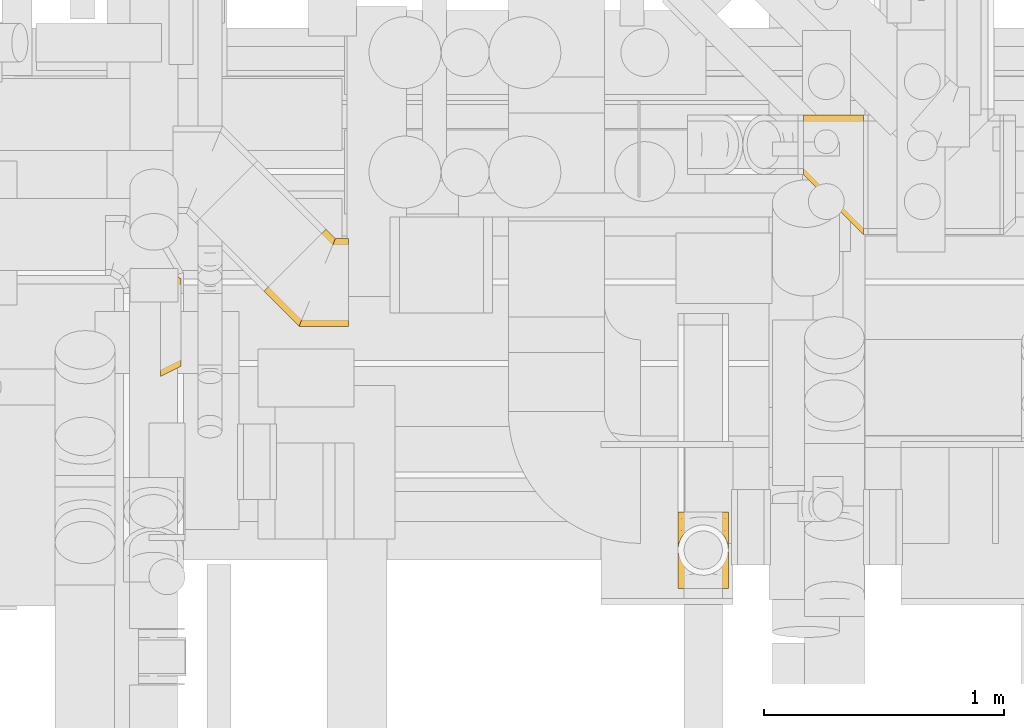
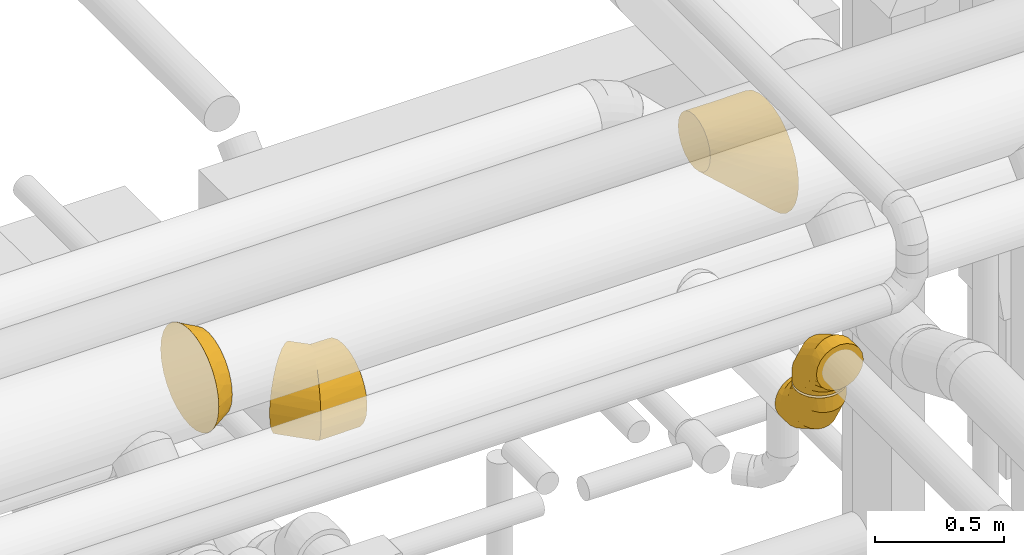
# One storey, part 14 of 337: 5 coverings.
"""IFC2X3 building model written with IfcOpenShell, lengths in millimetres."""

from ifc_helpers import new_model, entity, si_unit, converted_unit, derived_unit, direction, frame, origin, place, context, subcontext, project, spatial, faceted_brep, element, save


model = new_model("IFC2X3")

# Units and contexts
model_context = context("Model", 3, precision=0.01, world=origin(), true_north=direction((6.12303176911189e-17, 1.0)))
body_context = subcontext(model_context, "Body", "Model", "MODEL_VIEW")
ifc_project = project(units=[si_unit("LENGTHUNIT", "METRE", prefix="MILLI"), si_unit("AREAUNIT", "SQUARE_METRE"), si_unit("VOLUMEUNIT", "CUBIC_METRE"), converted_unit("PLANEANGLEUNIT", "DEGREE", entity("IfcRatioMeasure", 0.0174532925199433), si_unit("PLANEANGLEUNIT", "RADIAN"), dimensions=[0, 0, 0, 0, 0, 0, 0]), si_unit("MASSUNIT", "GRAM", prefix="KILO"), derived_unit("MASSDENSITYUNIT", [(si_unit("MASSUNIT", "GRAM", prefix="KILO"), 1), (si_unit("LENGTHUNIT", "METRE"), -3)]), derived_unit("MOMENTOFINERTIAUNIT", [(si_unit("LENGTHUNIT", "METRE"), 4)]), si_unit("TIMEUNIT", "SECOND"), si_unit("FREQUENCYUNIT", "HERTZ"), si_unit("THERMODYNAMICTEMPERATUREUNIT", "DEGREE_CELSIUS"), derived_unit("THERMALTRANSMITTANCEUNIT", [(si_unit("MASSUNIT", "GRAM", prefix="KILO"), 1), (si_unit("THERMODYNAMICTEMPERATUREUNIT", "KELVIN"), -1), (si_unit("TIMEUNIT", "SECOND"), -3)]), derived_unit("VOLUMETRICFLOWRATEUNIT", [(si_unit("LENGTHUNIT", "METRE"), 3), (si_unit("TIMEUNIT", "SECOND"), -1)]), derived_unit("MASSFLOWRATEUNIT", [(si_unit("MASSUNIT", "GRAM", prefix="KILO"), 1), (si_unit("TIMEUNIT", "SECOND"), -1)]), derived_unit("ROTATIONALFREQUENCYUNIT", [(si_unit("TIMEUNIT", "SECOND"), -1)]), si_unit("ELECTRICCURRENTUNIT", "AMPERE"), si_unit("ELECTRICVOLTAGEUNIT", "VOLT"), si_unit("POWERUNIT", "WATT"), si_unit("FORCEUNIT", "NEWTON", prefix="KILO"), si_unit("ILLUMINANCEUNIT", "LUX"), si_unit("LUMINOUSFLUXUNIT", "LUMEN"), si_unit("LUMINOUSINTENSITYUNIT", "CANDELA"), derived_unit("USERDEFINED", [(si_unit("MASSUNIT", "GRAM", prefix="KILO"), -1), (si_unit("LENGTHUNIT", "METRE"), -2), (si_unit("TIMEUNIT", "SECOND"), 3), (si_unit("LUMINOUSFLUXUNIT", "LUMEN"), 1)]), derived_unit("LINEARVELOCITYUNIT", [(si_unit("LENGTHUNIT", "METRE"), 1), (si_unit("TIMEUNIT", "SECOND"), -1)]), si_unit("PRESSUREUNIT", "PASCAL"), derived_unit("USERDEFINED", [(si_unit("LENGTHUNIT", "METRE"), -2), (si_unit("MASSUNIT", "GRAM", prefix="KILO"), 1), (si_unit("TIMEUNIT", "SECOND"), -2)]), derived_unit("LINEARFORCEUNIT", [(si_unit("MASSUNIT", "GRAM", prefix="KILO"), 1), (si_unit("LENGTHUNIT", "METRE"), 1), (si_unit("TIMEUNIT", "SECOND"), -2), (si_unit("LENGTHUNIT", "METRE"), -1)]), derived_unit("PLANARFORCEUNIT", [(si_unit("MASSUNIT", "GRAM", prefix="KILO"), 1), (si_unit("LENGTHUNIT", "METRE"), 1), (si_unit("TIMEUNIT", "SECOND"), -2), (si_unit("LENGTHUNIT", "METRE"), -2)])], contexts=[model_context])

# Site, building, storey
site_placement = place(None, origin())
site = spatial("IfcSite", under=ifc_project, at=site_placement, CompositionType="ELEMENT")
building_placement = place(site_placement, origin())
building = spatial("IfcBuilding", under=site, at=building_placement, CompositionType="ELEMENT")
storey_placement = place(building_placement, origin())
storey = spatial("IfcBuildingStorey", under=building, at=storey_placement, CompositionType="ELEMENT", Elevation=0.0)

# Coverings
covering_1_placement = place(storey_placement, frame((54791.45, 9091.79, 2915.91)))
element("IfcCovering", 1, at=covering_1_placement, inside=storey, PredefinedType="INSULATION", context=body_context, shape_type="Brep", body=[
    faceted_brep([(353.38, 366.6, 184.1), (353.38, 360.38, 231.33), (353.38, 342.14, 275.35), (353.38, 313.14, 313.14), (353.38, 275.35, 342.14), (353.38, 231.33, 360.38), (353.38, 184.1, 366.6), (353.38, 136.86, 360.38), (353.38, 92.85, 342.14), (353.38, 55.05, 313.14), (353.38, 26.05, 275.35), (353.38, 7.81, 231.33), (353.38, 1.6, 184.1), (353.38, 7.81, 136.86), (353.38, 26.05, 92.85), (353.38, 55.05, 55.05), (353.38, 92.85, 26.05), (353.38, 136.86, 7.81), (353.38, 184.1, 1.6), (353.38, 231.33, 7.81), (353.38, 275.35, 26.05), (353.38, 313.14, 55.05), (353.38, 342.14, 92.85), (353.38, 360.38, 136.86), (18.88, 164.6, 92.85), (5.99, 151.71, 136.86), (1.6, 147.31, 184.1), (5.99, 151.71, 231.33), (18.88, 164.6, 275.35), (39.39, 185.11, 313.14), (66.12, 211.83, 342.14), (97.24, 242.96, 360.38), (130.64, 276.36, 366.6), (164.04, 309.76, 360.38), (195.17, 340.88, 342.14), (221.89, 367.61, 313.14), (242.4, 388.11, 275.35), (255.29, 401.01, 231.33), (259.69, 405.4, 184.1), (255.29, 401.01, 136.86), (242.4, 388.11, 92.85), (221.89, 367.61, 55.05), (195.17, 340.88, 26.05), (164.04, 309.76, 7.81), (130.64, 276.36, 1.6), (97.24, 242.96, 7.81), (66.12, 211.83, 26.05), (39.39, 185.11, 55.05), (147.31, 1.6, 184.1), (149.2, 6.17, 224.71), (154.8, 19.67, 263.28), (163.8, 41.41, 297.88), (175.77, 70.31, 326.78), (190.1, 104.91, 348.52), (206.08, 143.49, 362.02), (222.9, 184.1, 366.6), (239.72, 224.71, 362.02), (255.7, 263.28, 348.52), (270.04, 297.88, 326.78), (282.01, 326.78, 297.88), (291.01, 348.52, 263.28), (296.6, 362.02, 224.71), (298.5, 366.6, 184.1), (291.01, 348.52, 104.91), (282.01, 326.78, 70.31), (296.6, 362.02, 143.49), (270.04, 297.88, 41.41), (255.7, 263.28, 19.67), (239.72, 224.71, 6.17), (222.9, 184.1, 1.6), (206.08, 143.49, 6.17), (190.1, 104.91, 19.67), (175.77, 70.31, 41.41), (163.8, 41.41, 70.31), (154.8, 19.67, 104.91), (149.2, 6.17, 143.49)], [[[0, 1, 2, 3, 4, 5, 6, 7, 8, 9, 10, 11, 12, 13, 14, 15, 16, 17, 18, 19, 20, 21, 22, 23]], [[24, 25, 26, 27, 28, 29, 30, 31, 32, 33, 34, 35, 36, 37, 38, 39, 40, 41, 42, 43, 44, 45, 46, 47]], [[26, 48, 49]], [[27, 49, 50]], [[26, 49, 27]], [[28, 51, 29]], [[28, 27, 50]], [[51, 28, 50]], [[30, 52, 53]], [[31, 53, 54]], [[32, 54, 55]], [[29, 52, 30]], [[30, 53, 31]], [[54, 32, 31]], [[52, 29, 51]], [[56, 57, 33]], [[55, 56, 32]], [[32, 56, 33]], [[34, 58, 35]], [[34, 33, 57]], [[58, 34, 57]], [[59, 60, 36]], [[61, 62, 38]], [[60, 61, 37]], [[35, 59, 36]], [[36, 60, 37]], [[61, 38, 37]], [[59, 35, 58]], [[63, 64, 40]], [[65, 63, 39]], [[62, 65, 38]], [[38, 65, 39]], [[63, 40, 39]], [[64, 41, 40]], [[66, 67, 42]], [[68, 69, 44]], [[67, 68, 43]], [[41, 66, 42]], [[42, 67, 43]], [[68, 44, 43]], [[66, 41, 64]], [[45, 70, 71]], [[46, 71, 72]], [[69, 70, 44]], [[44, 70, 45]], [[71, 46, 45]], [[72, 47, 46]], [[24, 73, 74]], [[74, 75, 25]], [[48, 26, 75]], [[47, 73, 24]], [[24, 74, 25]], [[75, 26, 25]], [[73, 47, 72]], [[11, 10, 50]], [[12, 11, 49]], [[48, 12, 49]], [[49, 11, 50]], [[10, 51, 50]], [[10, 9, 51]], [[52, 9, 8]], [[53, 8, 7]], [[54, 7, 6]], [[52, 8, 53]], [[53, 7, 54]], [[6, 55, 54]], [[9, 52, 51]], [[56, 6, 5]], [[57, 5, 4]], [[56, 55, 6]], [[58, 57, 4]], [[56, 5, 57]], [[4, 3, 58]], [[59, 3, 2]], [[60, 2, 1]], [[61, 1, 0]], [[60, 59, 2]], [[62, 61, 0]], [[60, 1, 61]], [[3, 59, 58]], [[65, 0, 23]], [[63, 23, 22]], [[65, 62, 0]], [[64, 63, 22]], [[65, 23, 63]], [[22, 21, 64]], [[66, 21, 20]], [[67, 20, 19]], [[68, 19, 18]], [[67, 66, 20]], [[69, 68, 18]], [[67, 19, 68]], [[21, 66, 64]], [[70, 18, 17]], [[71, 17, 16]], [[69, 18, 70]], [[71, 70, 17]], [[72, 71, 16]], [[16, 15, 72]], [[73, 15, 14]], [[74, 14, 13]], [[75, 13, 12]], [[73, 14, 74]], [[75, 74, 13]], [[48, 75, 12]], [[15, 73, 72]]]),
])
covering_2_placement = place(storey_placement, frame((56516.69, 8053.58, 2993.4)))
element("IfcCovering", 2, at=covering_2_placement, inside=storey, PredefinedType="INSULATION", context=body_context, shape_type="Brep", body=[
    faceted_brep([(1.6, 106.6, 266.6), (6.73, 74.15, 266.6), (21.65, 44.88, 266.6), (44.88, 21.65, 266.6), (74.15, 6.73, 266.6), (106.6, 1.6, 266.6), (139.04, 6.73, 266.6), (168.31, 21.65, 266.6), (191.54, 44.88, 266.6), (206.46, 74.15, 266.6), (211.6, 106.6, 266.6), (206.46, 139.04, 266.6), (191.54, 168.31, 266.6), (168.31, 191.54, 266.6), (139.04, 206.46, 266.6), (106.6, 211.6, 266.6), (74.15, 206.46, 266.6), (44.88, 191.54, 266.6), (21.65, 168.31, 266.6), (6.73, 139.04, 266.6), (159.1, 266.6, 15.66), (133.77, 266.6, 5.17), (106.6, 266.6, 1.6), (79.42, 266.6, 5.17), (54.1, 266.6, 15.66), (32.35, 266.6, 32.35), (15.66, 266.6, 54.1), (5.17, 266.6, 79.42), (1.6, 266.6, 106.6), (5.17, 266.6, 133.77), (15.66, 266.6, 159.1), (32.35, 266.6, 180.84), (54.1, 266.6, 197.53), (79.42, 266.6, 208.02), (106.6, 266.6, 211.6), (133.77, 266.6, 208.02), (159.1, 266.6, 197.53), (180.84, 266.6, 180.84), (197.53, 266.6, 159.1), (208.02, 266.6, 133.77), (211.6, 266.6, 106.6), (208.02, 266.6, 79.42), (197.53, 266.6, 54.1), (180.84, 266.6, 32.35), (106.6, 195.59, 1.6), (79.42, 196.55, 5.17), (54.1, 199.36, 15.66), (32.35, 203.83, 32.35), (15.66, 209.66, 54.1), (5.17, 216.44, 79.42), (1.6, 223.72, 106.6), (5.17, 231.01, 133.77), (15.66, 237.79, 159.1), (32.35, 243.62, 180.84), (54.1, 248.09, 197.53), (79.42, 250.9, 208.02), (106.6, 251.86, 211.6), (133.77, 250.9, 208.02), (159.1, 248.09, 197.53), (180.84, 243.62, 180.84), (208.02, 231.01, 133.77), (211.6, 223.72, 106.6), (197.53, 237.79, 159.1), (208.02, 216.44, 79.42), (197.53, 209.66, 54.1), (180.84, 203.83, 32.35), (159.1, 199.36, 15.66), (133.77, 196.55, 5.17), (106.6, 72.6, 72.6), (79.42, 75.22, 75.22), (54.1, 82.9, 82.9), (32.35, 95.12, 95.12), (15.66, 111.03, 111.03), (5.17, 129.57, 129.57), (1.6, 149.47, 149.47), (5.17, 169.36, 169.36), (15.66, 187.9, 187.9), (32.35, 203.82, 203.82), (54.1, 216.03, 216.03), (79.42, 223.71, 223.71), (106.6, 226.33, 226.33), (133.77, 223.71, 223.71), (159.1, 216.03, 216.03), (180.84, 203.82, 203.82), (208.02, 169.36, 169.36), (211.6, 149.47, 149.47), (197.53, 187.9, 187.9), (208.02, 129.57, 129.57), (197.53, 111.03, 111.03), (180.84, 95.12, 95.12), (159.1, 82.9, 82.9), (133.77, 75.22, 75.22), (106.6, 1.6, 195.59), (79.42, 5.17, 196.55), (54.1, 15.66, 199.36), (32.35, 32.35, 203.83), (15.66, 54.1, 209.66), (5.17, 79.42, 216.44), (1.6, 106.6, 223.72), (5.17, 133.77, 231.01), (15.66, 159.1, 237.79), (32.35, 180.84, 243.62), (54.1, 197.53, 248.09), (79.42, 208.02, 250.9), (106.6, 211.6, 251.86), (133.77, 208.02, 250.9), (159.1, 197.53, 248.09), (180.84, 180.84, 243.62), (208.02, 133.77, 231.01), (211.6, 106.6, 223.72), (197.53, 159.1, 237.79), (208.02, 79.42, 216.44), (197.53, 54.1, 209.66), (180.84, 32.35, 203.83), (159.1, 15.66, 199.36), (133.77, 5.17, 196.55)], [[[0, 1, 2, 3, 4, 5, 6, 7, 8, 9, 10, 11, 12, 13, 14, 15, 16, 17, 18, 19]], [[20, 21, 22, 23, 24, 25, 26, 27, 28, 29, 30, 31, 32, 33, 34, 35, 36, 37, 38, 39, 40, 41, 42, 43]], [[22, 44, 45, 23]], [[23, 45, 46, 24]], [[24, 46, 47, 25]], [[25, 47, 48, 26]], [[26, 48, 49, 27]], [[50, 28, 27, 49]], [[51, 52, 30, 29]], [[50, 51, 29, 28]], [[53, 31, 30, 52]], [[54, 55, 33, 32]], [[54, 32, 31, 53]], [[56, 34, 33, 55]], [[57, 58, 36, 35]], [[56, 57, 35, 34]], [[37, 36, 58, 59]], [[60, 61, 40, 39]], [[62, 60, 39, 38]], [[59, 62, 38, 37]], [[41, 40, 61, 63]], [[42, 41, 63, 64]], [[64, 65, 43, 42]], [[21, 20, 66, 67]], [[22, 21, 67, 44]], [[65, 66, 20, 43]], [[45, 44, 68, 69]], [[46, 45, 69, 70]], [[70, 71, 47, 46]], [[48, 47, 71, 72]], [[49, 48, 72, 73]], [[50, 49, 73, 74]], [[75, 76, 52, 51]], [[74, 75, 51, 50]], [[53, 52, 76, 77]], [[78, 79, 55, 54]], [[77, 78, 54, 53]], [[56, 55, 79, 80]], [[81, 82, 58, 57]], [[80, 81, 57, 56]], [[59, 58, 82, 83]], [[84, 85, 61, 60]], [[86, 84, 60, 62]], [[83, 86, 62, 59]], [[63, 61, 85, 87]], [[64, 63, 87, 88]], [[65, 64, 88, 89]], [[67, 66, 90, 91]], [[44, 67, 91, 68]], [[89, 90, 66, 65]], [[69, 68, 92, 93]], [[70, 69, 93, 94]], [[94, 95, 71, 70]], [[72, 71, 95, 96]], [[73, 72, 96, 97]], [[74, 73, 97, 98]], [[99, 100, 76, 75]], [[98, 99, 75, 74]], [[77, 76, 100, 101]], [[102, 103, 79, 78]], [[101, 102, 78, 77]], [[80, 79, 103, 104]], [[105, 106, 82, 81]], [[104, 105, 81, 80]], [[83, 82, 106, 107]], [[108, 109, 85, 84]], [[110, 108, 84, 86]], [[107, 110, 86, 83]], [[87, 85, 109, 111]], [[88, 87, 111, 112]], [[89, 88, 112, 113]], [[91, 90, 114, 115]], [[68, 91, 115, 92]], [[113, 114, 90, 89]], [[93, 5, 4]], [[94, 4, 3]], [[5, 93, 92]], [[93, 4, 94]], [[3, 95, 94]], [[96, 2, 1]], [[97, 1, 0]], [[95, 2, 96]], [[96, 1, 97]], [[0, 98, 97]], [[2, 95, 3]], [[99, 0, 19]], [[100, 19, 18]], [[99, 98, 0]], [[100, 99, 19]], [[18, 101, 100]], [[102, 17, 16]], [[103, 16, 15]], [[102, 101, 17]], [[104, 103, 15]], [[102, 16, 103]], [[17, 101, 18]], [[105, 15, 14]], [[106, 14, 13]], [[105, 104, 15]], [[106, 105, 14]], [[13, 107, 106]], [[110, 12, 11]], [[108, 11, 10]], [[110, 107, 12]], [[109, 108, 10]], [[110, 11, 108]], [[12, 107, 13]], [[9, 8, 112]], [[10, 9, 111]], [[10, 111, 109]], [[111, 9, 112]], [[8, 113, 112]], [[114, 7, 6]], [[115, 6, 5]], [[113, 7, 114]], [[115, 114, 6]], [[92, 115, 5]], [[7, 113, 8]]]),
])
covering_3_placement = place(storey_placement, frame((56516.69, 8000.18, 3270.0)))
element("IfcCovering", 3, at=covering_3_placement, inside=storey, PredefinedType="INSULATION", context=body_context, shape_type="Brep", body=[
    faceted_brep([(191.54, 0.0, 98.28), (206.46, 0.0, 127.55), (211.6, 0.0, 160.0), (206.46, 0.0, 192.45), (191.54, 0.0, 221.72), (168.31, 0.0, 244.95), (139.04, 0.0, 259.86), (106.6, 0.0, 265.0), (74.15, 0.0, 259.86), (44.88, 0.0, 244.95), (21.65, 0.0, 221.72), (6.73, 0.0, 192.45), (1.6, 0.0, 160.0), (6.73, 0.0, 127.55), (21.65, 0.0, 98.28), (44.88, 0.0, 75.05), (74.15, 0.0, 60.14), (106.6, 0.0, 55.0), (139.04, 0.0, 60.14), (168.31, 0.0, 75.05), (54.1, 250.93, 0.0), (79.42, 261.42, 0.0), (106.6, 265.0, 0.0), (133.77, 261.42, 0.0), (159.1, 250.93, 0.0), (180.84, 234.25, 0.0), (197.53, 212.5, 0.0), (208.02, 187.18, 0.0), (211.6, 160.0, 0.0), (208.02, 132.82, 0.0), (197.53, 107.5, 0.0), (180.84, 85.75, 0.0), (159.1, 69.07, 0.0), (133.77, 58.58, 0.0), (106.6, 55.0, 0.0), (79.42, 58.58, 0.0), (54.1, 69.07, 0.0), (32.35, 85.75, 0.0), (15.66, 107.5, 0.0), (5.17, 132.82, 0.0), (1.6, 160.0, 0.0), (5.17, 187.18, 0.0), (15.66, 212.5, 0.0), (32.35, 234.25, 0.0), (106.6, 265.0, 71.01), (133.77, 261.42, 70.05), (159.1, 250.93, 67.24), (180.84, 234.25, 62.77), (197.53, 212.5, 56.94), (208.02, 187.18, 50.15), (211.6, 160.0, 42.87), (208.02, 132.82, 35.59), (197.53, 107.5, 28.8), (180.84, 85.75, 22.98), (159.1, 69.07, 18.51), (133.77, 58.58, 15.7), (106.6, 55.0, 14.74), (79.42, 58.58, 15.7), (54.1, 69.07, 18.51), (32.35, 85.75, 22.98), (5.17, 132.82, 35.59), (1.6, 160.0, 42.87), (15.66, 107.5, 28.8), (5.17, 187.18, 50.15), (15.66, 212.5, 56.94), (32.35, 234.25, 62.77), (54.1, 250.93, 67.24), (79.42, 261.42, 70.05), (106.6, 193.99, 193.99), (133.77, 191.37, 191.37), (159.1, 183.7, 183.7), (180.84, 171.48, 171.48), (197.53, 155.56, 155.56), (208.02, 137.02, 137.02), (211.6, 117.13, 117.13), (208.02, 97.23, 97.23), (197.53, 78.7, 78.7), (180.84, 62.78, 62.78), (159.1, 50.56, 50.56), (133.77, 42.88, 42.88), (106.6, 40.26, 40.26), (79.42, 42.88, 42.88), (54.1, 50.56, 50.56), (32.35, 62.78, 62.78), (5.17, 97.23, 97.23), (1.6, 117.13, 117.13), (15.66, 78.7, 78.7), (5.17, 137.02, 137.02), (15.66, 155.56, 155.56), (32.35, 171.48, 171.48), (54.1, 183.7, 183.7), (79.42, 191.37, 191.37), (106.6, 71.01, 265.0), (133.77, 70.05, 261.42), (159.1, 67.24, 250.93), (180.84, 62.77, 234.25), (197.53, 56.94, 212.5), (208.02, 50.15, 187.18), (211.6, 42.87, 160.0), (208.02, 35.59, 132.82), (197.53, 28.8, 107.5), (180.84, 22.98, 85.75), (159.1, 18.51, 69.07), (133.77, 15.7, 58.58), (106.6, 14.74, 55.0), (79.42, 15.7, 58.58), (54.1, 18.51, 69.07), (32.35, 22.98, 85.75), (5.17, 35.59, 132.82), (1.6, 42.87, 160.0), (15.66, 28.8, 107.5), (5.17, 50.15, 187.18), (15.66, 56.94, 212.5), (32.35, 62.77, 234.25), (54.1, 67.24, 250.93), (79.42, 70.05, 261.42)], [[[0, 1, 2, 3, 4, 5, 6, 7, 8, 9, 10, 11, 12, 13, 14, 15, 16, 17, 18, 19]], [[20, 21, 22, 23, 24, 25, 26, 27, 28, 29, 30, 31, 32, 33, 34, 35, 36, 37, 38, 39, 40, 41, 42, 43]], [[22, 44, 45, 23]], [[23, 45, 46, 24]], [[24, 46, 47, 25]], [[25, 47, 48, 26]], [[26, 48, 49, 27]], [[50, 28, 27, 49]], [[51, 52, 30, 29]], [[50, 51, 29, 28]], [[53, 31, 30, 52]], [[54, 55, 33, 32]], [[54, 32, 31, 53]], [[56, 34, 33, 55]], [[57, 58, 36, 35]], [[56, 57, 35, 34]], [[37, 36, 58, 59]], [[60, 61, 40, 39]], [[62, 60, 39, 38]], [[59, 62, 38, 37]], [[41, 40, 61, 63]], [[42, 41, 63, 64]], [[64, 65, 43, 42]], [[21, 20, 66, 67]], [[22, 21, 67, 44]], [[65, 66, 20, 43]], [[44, 68, 69, 45]], [[45, 69, 70, 46]], [[70, 71, 47, 46]], [[48, 47, 71, 72]], [[49, 48, 72, 73]], [[50, 49, 73, 74]], [[75, 76, 52, 51]], [[74, 75, 51, 50]], [[53, 52, 76, 77]], [[78, 79, 55, 54]], [[77, 78, 54, 53]], [[56, 55, 79, 80]], [[81, 82, 58, 57]], [[80, 81, 57, 56]], [[59, 58, 82, 83]], [[84, 85, 61, 60]], [[86, 84, 60, 62]], [[83, 86, 62, 59]], [[63, 61, 85, 87]], [[64, 63, 87, 88]], [[65, 64, 88, 89]], [[67, 66, 90, 91]], [[44, 67, 91, 68]], [[89, 90, 66, 65]], [[68, 92, 93, 69]], [[69, 93, 94, 70]], [[94, 95, 71, 70]], [[72, 71, 95, 96]], [[73, 72, 96, 97]], [[74, 73, 97, 98]], [[99, 100, 76, 75]], [[98, 99, 75, 74]], [[77, 76, 100, 101]], [[102, 103, 79, 78]], [[101, 102, 78, 77]], [[80, 79, 103, 104]], [[105, 106, 82, 81]], [[104, 105, 81, 80]], [[83, 82, 106, 107]], [[108, 109, 85, 84]], [[110, 108, 84, 86]], [[107, 110, 86, 83]], [[87, 85, 109, 111]], [[88, 87, 111, 112]], [[89, 88, 112, 113]], [[91, 90, 114, 115]], [[68, 91, 115, 92]], [[113, 114, 90, 89]], [[93, 7, 6]], [[94, 6, 5]], [[7, 93, 92]], [[93, 6, 94]], [[5, 95, 94]], [[96, 4, 3]], [[97, 3, 2]], [[95, 4, 96]], [[96, 3, 97]], [[2, 98, 97]], [[4, 95, 5]], [[99, 2, 1]], [[100, 1, 0]], [[99, 98, 2]], [[100, 99, 1]], [[0, 101, 100]], [[102, 19, 18]], [[103, 18, 17]], [[102, 101, 19]], [[104, 103, 17]], [[102, 18, 103]], [[19, 101, 0]], [[105, 17, 16]], [[106, 16, 15]], [[105, 104, 17]], [[106, 105, 16]], [[15, 107, 106]], [[110, 14, 13]], [[108, 13, 12]], [[110, 107, 14]], [[109, 108, 12]], [[110, 13, 108]], [[14, 107, 15]], [[11, 10, 112]], [[12, 11, 111]], [[12, 111, 109]], [[111, 11, 112]], [[10, 113, 112]], [[114, 9, 8]], [[115, 8, 7]], [[113, 9, 114]], [[115, 114, 8]], [[92, 115, 7]], [[9, 113, 10]]]),
])
covering_4_placement = place(storey_placement, frame((57041.08, 9473.4, 2914.23)))
element("IfcCovering", 4, at=covering_4_placement, inside=storey, PredefinedType="INSULATION", context=body_context, shape_type="Brep", body=[
    faceted_brep([(0.0, 257.71, 350.6), (0.0, 275.47, 385.45), (0.0, 303.12, 413.1), (0.0, 337.97, 430.86), (0.0, 354.07, 433.4), (0.0, 376.6, 436.97), (0.0, 402.26, 432.91), (0.0, 415.22, 430.86), (0.0, 450.07, 413.1), (0.0, 477.72, 385.45), (0.0, 495.48, 350.6), (0.0, 497.53, 337.64), (0.0, 501.6, 311.97), (0.0, 497.81, 288.08), (0.0, 495.48, 273.35), (0.0, 477.72, 238.5), (0.0, 450.07, 210.85), (0.0, 415.22, 193.09), (0.0, 400.49, 190.76), (0.0, 376.6, 186.97), (0.0, 355.05, 190.39), (0.0, 337.97, 193.09), (0.0, 303.12, 210.85), (0.0, 275.47, 238.5), (0.0, 257.71, 273.35), (0.0, 255.01, 290.43), (0.0, 251.6, 311.97), (0.0, 255.16, 334.5), (250.0, 251.6, 501.6), (250.0, 195.97, 495.33), (250.0, 143.12, 476.84), (250.0, 95.72, 447.05), (250.0, 56.14, 407.47), (250.0, 26.35, 360.07), (250.0, 7.86, 307.23), (250.0, 1.6, 251.6), (250.0, 7.86, 195.97), (250.0, 26.35, 143.12), (250.0, 56.14, 95.72), (250.0, 95.72, 56.14), (250.0, 143.12, 26.35), (250.0, 195.97, 7.86), (250.0, 251.6, 1.6), (250.0, 307.23, 7.86), (250.0, 360.07, 26.35), (250.0, 407.47, 56.14), (250.0, 447.05, 95.72), (250.0, 476.84, 143.12), (250.0, 495.33, 195.97), (250.0, 501.6, 251.6), (250.0, 495.33, 307.23), (250.0, 476.84, 360.07), (250.0, 447.05, 407.47), (250.0, 407.47, 447.05), (250.0, 360.07, 476.84), (250.0, 307.23, 495.33), (139.67, 498.58, 244.07), (139.67, 340.93, 86.43), (131.24, 376.99, 101.45), (131.69, 472.34, 178.63), (114.96, 448.15, 155.18), (137.06, 308.07, 85.34), (124.72, 314.24, 94.49), (131.24, 489.8, 214.27), (124.72, 501.6, 281.85), (131.69, 412.28, 118.57), (115.45, 501.6, 284.09), (140.0, 272.25, 86.21), (131.69, 209.21, 118.57), (131.69, 149.15, 178.63), (114.96, 190.08, 155.18), (137.06, 114.53, 278.87), (140.0, 114.64, 243.82), (131.24, 244.97, 101.45), (131.24, 132.15, 214.27), (131.89, 119.71, 280.12), (139.92, 114.72, 312.48), (131.69, 149.15, 381.7), (131.69, 209.21, 441.76), (114.96, 190.08, 413.24), (131.89, 310.65, 471.06), (139.92, 272.34, 470.1), (131.24, 132.15, 346.29), (131.24, 244.97, 459.1), (115.45, 318.87, 466.82), (139.13, 340.93, 469.96), (114.96, 448.15, 413.24), (131.69, 412.28, 441.76), (139.13, 498.62, 312.27), (131.24, 376.99, 459.1), (131.69, 472.34, 381.7), (131.24, 489.8, 346.29)], [[[0, 1, 2, 3, 4, 5, 6, 7, 8, 9, 10, 11, 12, 13, 14, 15, 16, 17, 18, 19, 20, 21, 22, 23, 24, 25, 26, 27]], [[28, 29, 30, 31, 32, 33, 34, 35, 36, 37, 38, 39, 40, 41, 42, 43, 44, 45, 46, 47, 48, 49, 50, 51, 52, 53, 54, 55]], [[49, 48, 56]], [[57, 58, 43]], [[47, 46, 59]], [[59, 60, 15]], [[57, 42, 61, 62]], [[48, 63, 56]], [[16, 15, 60]], [[63, 47, 59]], [[14, 63, 59]], [[13, 64, 56]], [[45, 60, 46]], [[60, 59, 46]], [[65, 58, 17]], [[44, 43, 58]], [[48, 47, 63]], [[58, 57, 17]], [[60, 45, 65]], [[45, 44, 65]], [[60, 65, 16]], [[65, 17, 16]], [[57, 18, 17]], [[65, 44, 58]], [[13, 56, 14]], [[62, 19, 18]], [[13, 12, 66, 64]], [[14, 59, 15]], [[56, 63, 14]], [[49, 56, 64]], [[42, 57, 43]], [[18, 57, 62]], [[20, 61, 67]], [[20, 19, 62, 61]], [[40, 39, 68]], [[69, 70, 38]], [[35, 71, 72]], [[41, 73, 67]], [[23, 22, 70]], [[73, 40, 68]], [[21, 73, 68]], [[42, 41, 67]], [[38, 70, 39]], [[72, 74, 36]], [[69, 74, 24]], [[41, 40, 73]], [[20, 67, 21]], [[74, 72, 24]], [[22, 68, 70]], [[38, 37, 69]], [[69, 37, 74]], [[69, 24, 23]], [[72, 25, 24]], [[21, 68, 22]], [[70, 69, 23]], [[37, 36, 74]], [[25, 71, 75, 26]], [[70, 68, 39]], [[67, 73, 21]], [[42, 67, 61]], [[35, 72, 36]], [[25, 72, 71]], [[27, 75, 76]], [[75, 27, 26]], [[33, 32, 77]], [[78, 79, 31]], [[28, 80, 81]], [[34, 82, 76]], [[2, 1, 79]], [[82, 33, 77]], [[0, 82, 77]], [[35, 34, 76]], [[31, 79, 32]], [[81, 83, 29]], [[78, 83, 3]], [[34, 33, 82]], [[27, 76, 0]], [[83, 81, 3]], [[1, 77, 79]], [[31, 30, 78]], [[78, 30, 83]], [[78, 3, 2]], [[81, 4, 3]], [[0, 77, 1]], [[79, 78, 2]], [[30, 29, 83]], [[4, 80, 84, 5]], [[79, 77, 32]], [[76, 82, 0]], [[76, 75, 71, 35]], [[28, 81, 29]], [[4, 81, 80]], [[6, 84, 85]], [[86, 87, 53]], [[54, 53, 87]], [[9, 8, 86]], [[88, 49, 64, 66]], [[55, 89, 85]], [[87, 86, 8]], [[89, 54, 87]], [[7, 89, 87]], [[28, 55, 85]], [[52, 86, 53]], [[7, 87, 8]], [[90, 91, 10]], [[66, 12, 11]], [[51, 50, 91]], [[10, 91, 11]], [[86, 52, 90]], [[52, 51, 90]], [[7, 6, 89]], [[90, 10, 9]], [[91, 88, 11]], [[86, 90, 9]], [[55, 54, 89]], [[84, 6, 5]], [[88, 91, 50]], [[90, 51, 91]], [[6, 85, 89]], [[85, 84, 80, 28]], [[49, 88, 50]], [[11, 88, 66]]]),
])
covering_5_placement = place(storey_placement, frame((54361.4, 8882.05, 3273.4)))
element("IfcCovering", 5, at=covering_5_placement, inside=storey, PredefinedType="INSULATION", context=body_context, shape_type="Brep", body=[
    faceted_brep([(85.0, 179.36, 402.88), (85.0, 135.35, 384.64), (85.0, 97.55, 355.64), (85.0, 68.55, 317.84), (85.0, 50.31, 273.83), (85.0, 44.1, 226.59), (85.0, 50.31, 179.36), (85.0, 68.55, 135.34), (85.0, 97.55, 97.55), (85.0, 135.35, 68.54), (85.0, 179.36, 50.31), (85.0, 226.6, 44.09), (85.0, 273.83, 50.31), (85.0, 317.85, 68.54), (85.0, 355.64, 97.55), (85.0, 384.64, 135.34), (85.0, 402.88, 179.36), (85.0, 409.1, 226.59), (85.0, 402.88, 273.83), (85.0, 384.64, 317.84), (85.0, 355.64, 355.64), (85.0, 317.85, 384.64), (85.0, 273.83, 402.88), (85.0, 226.6, 409.09), (0.0, 276.66, 445.95), (0.0, 324.22, 429.31), (0.0, 366.88, 402.51), (0.0, 402.51, 366.88), (0.0, 429.31, 324.22), (0.0, 445.95, 276.66), (0.0, 451.6, 226.6), (0.0, 445.95, 176.53), (0.0, 429.31, 128.97), (0.0, 402.51, 86.31), (0.0, 366.88, 50.68), (0.0, 324.22, 23.88), (0.0, 276.66, 7.24), (0.0, 226.6, 1.6), (0.0, 176.53, 7.24), (0.0, 128.97, 23.88), (0.0, 86.31, 50.68), (0.0, 50.68, 86.31), (0.0, 23.88, 128.97), (0.0, 7.24, 176.53), (0.0, 1.6, 226.6), (0.0, 7.24, 276.66), (0.0, 23.88, 324.22), (0.0, 50.68, 366.88), (0.0, 86.31, 402.51), (0.0, 128.97, 429.31), (0.0, 176.53, 445.95), (0.0, 226.6, 451.6), (40.52, 33.35, 158.97), (39.34, 52.74, 117.35), (39.0, 226.6, 21.09), (40.52, 158.97, 33.35), (39.0, 21.09, 226.59), (40.14, 78.98, 84.45), (39.34, 117.35, 52.74), (40.52, 294.22, 33.35), (39.34, 335.84, 52.74), (39.0, 432.1, 226.59), (40.52, 419.84, 158.97), (40.14, 368.74, 78.98), (39.34, 400.45, 117.35), (40.52, 419.84, 294.22), (39.34, 400.45, 335.84), (39.0, 226.6, 432.1), (40.52, 294.22, 419.84), (40.14, 374.21, 368.74), (39.34, 335.84, 400.45), (40.52, 158.97, 419.84), (39.34, 117.35, 400.45), (40.52, 33.35, 294.22), (40.14, 84.45, 374.21), (39.34, 52.74, 335.84)], [[[0, 1, 2, 3, 4, 5, 6, 7, 8, 9, 10, 11, 12, 13, 14, 15, 16, 17, 18, 19, 20, 21, 22, 23]], [[24, 25, 26, 27, 28, 29, 30, 31, 32, 33, 34, 35, 36, 37, 38, 39, 40, 41, 42, 43, 44, 45, 46, 47, 48, 49, 50, 51]], [[52, 42, 53]], [[54, 55, 38]], [[56, 6, 5]], [[56, 43, 52]], [[56, 44, 43]], [[38, 37, 54]], [[7, 6, 52]], [[53, 42, 41]], [[43, 42, 52]], [[56, 52, 6]], [[8, 7, 53]], [[57, 40, 58]], [[58, 40, 39]], [[53, 41, 57]], [[55, 39, 38]], [[41, 40, 57]], [[54, 11, 10]], [[9, 55, 10]], [[58, 8, 57]], [[58, 9, 8]], [[55, 9, 58]], [[55, 54, 10]], [[52, 53, 7]], [[8, 53, 57]], [[55, 58, 39]], [[59, 35, 60]], [[61, 62, 31]], [[54, 12, 11]], [[54, 36, 59]], [[54, 37, 36]], [[31, 30, 61]], [[13, 12, 59]], [[60, 35, 34]], [[36, 35, 59]], [[54, 59, 12]], [[14, 13, 60]], [[63, 33, 64]], [[64, 33, 32]], [[60, 34, 63]], [[62, 32, 31]], [[34, 33, 63]], [[61, 17, 16]], [[15, 62, 16]], [[64, 14, 63]], [[64, 15, 14]], [[62, 15, 64]], [[62, 61, 16]], [[59, 60, 13]], [[14, 60, 63]], [[62, 64, 32]], [[65, 28, 66]], [[67, 68, 24]], [[61, 18, 17]], [[61, 29, 65]], [[61, 30, 29]], [[24, 51, 67]], [[19, 18, 65]], [[66, 28, 27]], [[29, 28, 65]], [[61, 65, 18]], [[20, 19, 66]], [[69, 26, 70]], [[70, 26, 25]], [[66, 27, 69]], [[68, 25, 24]], [[27, 26, 69]], [[67, 23, 22]], [[21, 68, 22]], [[70, 20, 69]], [[70, 21, 20]], [[68, 21, 70]], [[68, 67, 22]], [[65, 66, 19]], [[20, 66, 69]], [[68, 70, 25]], [[71, 49, 72]], [[56, 73, 45]], [[67, 0, 23]], [[67, 50, 71]], [[67, 51, 50]], [[45, 44, 56]], [[1, 0, 71]], [[72, 49, 48]], [[50, 49, 71]], [[67, 71, 0]], [[2, 1, 72]], [[74, 47, 75]], [[75, 47, 46]], [[72, 48, 74]], [[73, 46, 45]], [[48, 47, 74]], [[56, 5, 4]], [[3, 73, 4]], [[75, 2, 74]], [[75, 3, 2]], [[73, 3, 75]], [[73, 56, 4]], [[71, 72, 1]], [[2, 72, 74]], [[73, 75, 46]]]),
])

save(model, "model.ifc")
